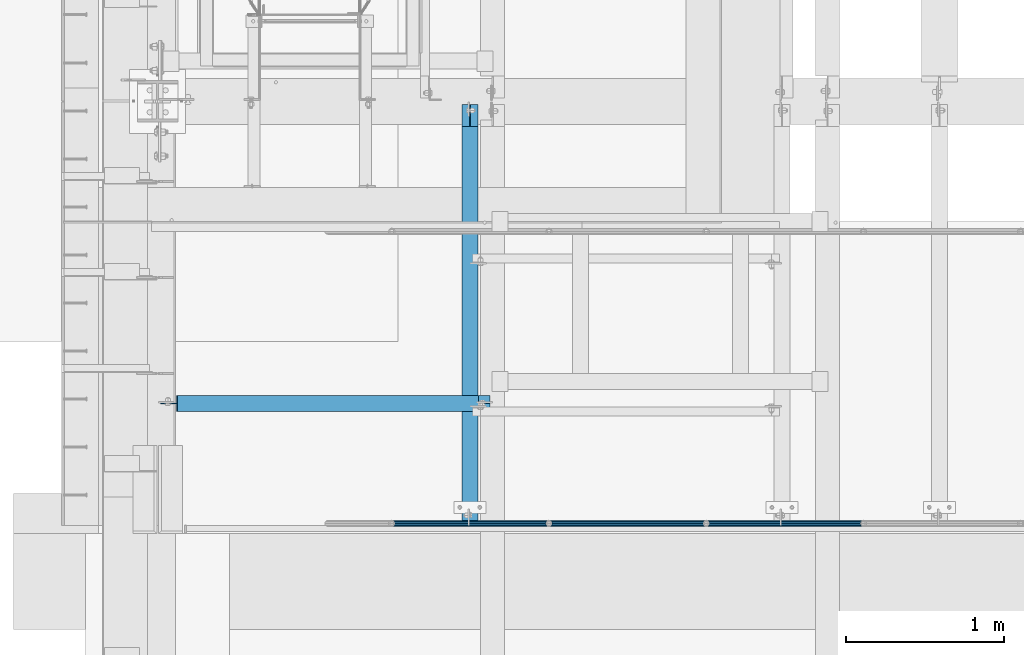
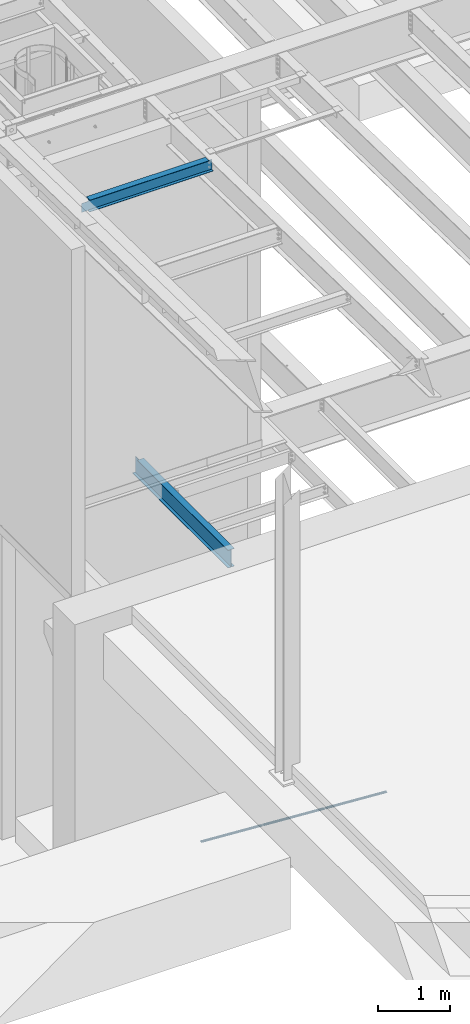
# One storey, part 1073 of 1763: 5 beams, 3 elements without a shape of their own.
"""IFC2X3 building model written with IfcOpenShell, lengths in millimetres."""

from ifc_helpers import new_model, si_unit, frame, origin_with_axes, place, context, subcontext, project, spatial, faceted_brep, material, type_object, element, aggregate, save


model = new_model("IFC2X3")

# Units and contexts
model_context = context("Model", 3, precision=1e-05, world=origin_with_axes())
body_context = subcontext(model_context, "Body", "Model", "MODEL_VIEW")
ifc_project = project(units=[si_unit("LENGTHUNIT", "METRE", prefix="MILLI"), si_unit("AREAUNIT", "SQUARE_METRE"), si_unit("VOLUMEUNIT", "CUBIC_METRE"), si_unit("MASSUNIT", "GRAM", prefix="KILO"), si_unit("TIMEUNIT", "SECOND"), si_unit("PLANEANGLEUNIT", "RADIAN"), si_unit("SOLIDANGLEUNIT", "STERADIAN"), si_unit("THERMODYNAMICTEMPERATUREUNIT", "DEGREE_CELSIUS"), si_unit("LUMINOUSINTENSITYUNIT", "LUMEN")], contexts=[model_context])

# Site, building, storey
site_placement = place(None, origin_with_axes())
site = spatial("IfcSite", under=ifc_project, at=site_placement, CompositionType="ELEMENT")
building_placement = place(site_placement, origin_with_axes())
building = spatial("IfcBuilding", under=site, at=building_placement, Name="Undefined", CompositionType="ELEMENT")
storey_placement = place(building_placement, origin_with_axes())
storey = spatial("IfcBuildingStorey", under=building, at=storey_placement, Name="Undefined", CompositionType="ELEMENT", Elevation=0.0)

# Assembly, beams
assembly_1_placement = place(storey_placement, origin_with_axes())
assembly_1 = element("IfcElementAssembly", 1, at=assembly_1_placement, inside=storey, Name="GUARDRAIL", AssemblyPlace="NOTDEFINED", PredefinedType="RIGID_FRAME")
ifc_material_1 = material()
beam_type_1 = type_object("IfcBeamType", PredefinedType="NOTDEFINED")
beam_1_placement = place(assembly_1_placement, frame((-84891.4958692838, 27343.0999999971, 342.725435582879), z_axis=(0.0, -1.0, 0.0), x_axis=(-0.997891522550524, 0.0, 0.0649038459707657)))
beam_1 = element("IfcBeam", 2, at=beam_1_placement, type_object=beam_type_1, material=ifc_material_1, Name="GUARDRAIL", context=body_context, shape_type="Brep", body=[
    faceted_brep([(1.45519152283669e-11, 1.81898940354586e-12, 19.0499999999993), (8.92561031517107, 9.52499999999873, 16.4977839420935), (10.1646410493704, -9.524999999996, 16.4977839420935), (10.1646410493704, -9.52499999999509, -16.4977839420935), (8.92561031517107, 9.52499999999873, -16.4977839420935), (1.45519152283669e-11, 1.81898940354586e-12, -19.0499999999993), (17.6056747381954, -16.4977839420881, -9.52500000000146), (17.2784488961188, -11.4667123799518, -9.52500000000146), (13.2411789904436, -7.68349999999555, -13.3082123799541), (10.6782988949999, 1.81898940354586e-12, -15.3669999999984), (12.2416941982665, 7.68350000000009, -13.3082123799541), (15.7868363965099, 11.4667123799545, -9.52500000000146), (15.4596105544624, 16.4977839420917, -9.52500000000146), (18.0907665723062, 15.3669999999984, 0.0), (17.8512206303712, 19.0499999999975, 0.0), (16.1615344449092, 13.3082123799541, -7.68349999999919), (16.1615344449092, 13.3082123799541, 7.68349999999919), (15.7868363965099, 11.4667123799545, 9.52500000000146), (15.4596105544624, 16.4977839420917, 9.52500000000146), (12.2416941982665, 7.68350000000009, 13.3082123799541), (10.6782988949999, 1.81898940354586e-12, 15.3669999999984), (13.2411789904436, -7.68349999999646, 13.3082123799541), (17.2784488961188, -11.4667123799518, 9.52500000000146), (17.6056747381954, -16.4977839420881, 9.52500000000146), (17.8926928863511, -13.3082123799504, 7.68349999999919), (20.0897361567768, -15.3669999999947, 0.0), (20.3292820987263, -19.0499999999938, 0.0), (17.8926928863511, -13.3082123799504, -7.68349999999919), (1000.15019855546, 2.72848410531878e-11, 19.0499999999993), (989.985557506108, 9.5250000000251, 16.4977839420935), (982.544523817283, 16.4977839421163, 9.52500000000146), (1000.15019855548, 2.81943357549608e-11, -19.0499999999993), (989.985557506108, 9.5250000000251, -16.4977839420935), (991.224588240293, -9.52499999997053, -16.4977839420935), (984.690588001031, -16.4977839420635, -9.52500000000146), (982.544523817283, 16.4977839421163, -9.52500000000146), (979.820916456767, 19.050000000022, 0.0), (982.257505670044, 13.3082123799786, 7.68349999999919), (980.060462398702, 15.3670000000229, 0.0), (982.87174965936, 11.46671237998, 9.52500000000146), (982.87174965936, 11.46671237998, -9.52500000000146), (982.257505670044, 13.3082123799786, -7.68349999999919), (986.909019565966, 7.68350000002556, -13.3082123799541), (989.47189966141, 2.81943357549608e-11, -15.3669999999984), (987.908504358144, -7.68349999997099, -13.3082123799541), (984.363362158969, -11.4667123799254, -9.52500000000146), (983.988664111486, -13.3082123799259, -7.68349999999919), (982.059431983173, -15.3669999999702, 0.0), (982.298977925122, -19.0499999999693, 0.0), (984.690588001031, -16.4977839420635, 9.52500000000146), (991.224588240293, -9.52499999997053, 16.4977839420935), (984.363362158969, -11.4667123799254, 9.52500000000146), (987.908504358144, -7.68349999997099, 13.3082123799541), (989.47189966141, 2.72848410531878e-11, 15.3669999999984), (986.909019565966, 7.68350000002465, 13.3082123799541), (983.988664111486, -13.3082123799259, 7.68349999999919)], [[[0, 1, 2]], [[3, 4, 5]], [[6, 7, 8, 9, 10, 11, 12, 4, 3]], [[13, 14, 12, 11, 15]], [[16, 17, 18, 14, 13]], [[2, 1, 18, 17, 19, 20, 21, 22, 23]], [[23, 22, 24, 25, 26]], [[26, 25, 27, 7, 6]], [[28, 29, 1, 0]], [[29, 30, 18, 1]], [[31, 32, 33]], [[33, 34, 6, 3]], [[31, 33, 3, 5]], [[32, 31, 5, 4]], [[35, 32, 4, 12]], [[36, 35, 12, 14]], [[30, 36, 14, 18]], [[37, 38, 36, 30, 39]], [[40, 35, 36, 38, 41]], [[33, 32, 35, 40, 42, 43, 44, 45, 34]], [[34, 45, 46, 47, 48]], [[34, 48, 26, 6]], [[49, 50, 2, 23]], [[48, 49, 23, 26]], [[50, 28, 0, 2]], [[28, 50, 29]], [[49, 51, 52, 53, 54, 39, 30, 29, 50]], [[48, 47, 55, 51, 49]], [[55, 47, 25, 24]], [[21, 52, 51, 55, 24, 22]], [[53, 52, 21, 20]], [[54, 53, 20, 19]], [[37, 39, 54, 19, 17, 16]], [[38, 37, 16, 13]], [[41, 38, 13, 15]], [[10, 42, 40, 41, 15, 11]], [[43, 42, 10, 9]], [[44, 43, 9, 8]], [[46, 45, 44, 8, 7, 27]], [[47, 46, 27, 25]]]),
])
beam_2_placement = place(assembly_1_placement, frame((-83893.4544648736, 27343.0999999971, 277.811841144733), z_axis=(0.0, -1.0, 0.0), x_axis=(-0.997891522550524, 0.0, 0.0649038459707657)))
beam_2 = element("IfcBeam", 3, at=beam_2_placement, type_object=beam_type_1, material=ifc_material_1, Name="GUARDRAIL", context=body_context, shape_type="Brep", body=[
    faceted_brep([(1000.15019855548, 2.81943357549608e-11, -19.0499999999993), (989.985557506108, 9.5250000000251, -16.4977839420935), (991.224588240293, -9.52499999997053, -16.4977839420935), (982.257505670044, 13.3082123799786, 7.68349999999919), (980.060462398702, 15.3670000000229, 0.0), (979.820916456767, 19.050000000022, 0.0), (982.544523817283, 16.4977839421163, 9.52500000000146), (982.87174965936, 11.46671237998, 9.52500000000146), (982.87174965936, 11.46671237998, -9.52500000000146), (982.544523817283, 16.4977839421163, -9.52500000000146), (982.257505670044, 13.3082123799786, -7.68349999999919), (986.909019565966, 7.68350000002556, -13.3082123799541), (989.47189966141, 2.81943357549608e-11, -15.3669999999984), (987.908504358144, -7.68349999997099, -13.3082123799541), (984.363362158969, -11.4667123799254, -9.52500000000146), (984.690588001031, -16.4977839420635, -9.52500000000146), (983.988664111486, -13.3082123799259, -7.68349999999919), (982.059431983173, -15.3669999999702, 0.0), (982.298977925122, -19.0499999999693, 0.0), (983.988664111486, -13.3082123799259, 7.68349999999919), (984.363362158969, -11.4667123799254, 9.52500000000146), (984.690588001031, -16.4977839420635, 9.52500000000146), (1000.15019855546, 2.72848410531878e-11, 19.0499999999993), (991.224588240293, -9.52499999997053, 16.4977839420935), (989.985557506108, 9.5250000000251, 16.4977839420935), (987.908504358144, -7.68349999997099, 13.3082123799541), (989.47189966141, 2.72848410531878e-11, 15.3669999999984), (986.909019565966, 7.68350000002465, 13.3082123799541), (8.92561031517107, 9.52499999999873, -16.4977839420935), (15.4596105544624, 16.4977839420917, -9.52500000000146), (17.8512206303712, 19.0499999999975, 0.0), (18.0907665723062, 15.3669999999984, 0.0), (15.7868363965099, 11.4667123799545, -9.52500000000146), (16.1615344449092, 13.3082123799541, -7.68349999999919), (16.1615344449092, 13.3082123799541, 7.68349999999919), (15.7868363965099, 11.4667123799545, 9.52500000000146), (15.4596105544624, 16.4977839420917, 9.52500000000146), (8.92561031517107, 9.52499999999873, 16.4977839420935), (1.45519152283669e-11, 1.81898940354586e-12, 19.0499999999993), (10.1646410493704, -9.524999999996, 16.4977839420935), (10.1646410493704, -9.52499999999509, -16.4977839420935), (1.45519152283669e-11, 1.81898940354586e-12, -19.0499999999993), (17.6056747381954, -16.4977839420881, -9.52500000000146), (20.3292820987263, -19.0499999999938, 0.0), (17.6056747381954, -16.4977839420881, 9.52500000000146), (17.2784488961188, -11.4667123799518, -9.52500000000146), (13.2411789904436, -7.68349999999555, -13.3082123799541), (10.6782988949999, 1.81898940354586e-12, -15.3669999999984), (12.2416941982665, 7.68350000000009, -13.3082123799541), (20.0897361567768, -15.3669999999947, 0.0), (17.8926928863511, -13.3082123799504, -7.68349999999919), (17.2784488961188, -11.4667123799518, 9.52500000000146), (17.8926928863511, -13.3082123799504, 7.68349999999919), (12.2416941982665, 7.68350000000009, 13.3082123799541), (10.6782988949999, 1.81898940354586e-12, 15.3669999999984), (13.2411789904436, -7.68349999999646, 13.3082123799541)], [[[0, 1, 2]], [[3, 4, 5, 6, 7]], [[8, 9, 5, 4, 10]], [[2, 1, 9, 8, 11, 12, 13, 14, 15]], [[15, 14, 16, 17, 18]], [[18, 17, 19, 20, 21]], [[22, 23, 24]], [[21, 20, 25, 26, 27, 7, 6, 24, 23]], [[9, 1, 28, 29]], [[5, 9, 29, 30]], [[31, 30, 29, 32, 33]], [[34, 35, 36, 30, 31]], [[6, 5, 30, 36]], [[24, 6, 36, 37]], [[22, 24, 37, 38]], [[38, 37, 39]], [[0, 2, 40, 41]], [[2, 15, 42, 40]], [[15, 18, 43, 42]], [[18, 21, 44, 43]], [[21, 23, 39, 44]], [[23, 22, 38, 39]], [[1, 0, 41, 28]], [[40, 28, 41]], [[42, 45, 46, 47, 48, 32, 29, 28, 40]], [[43, 49, 50, 45, 42]], [[44, 51, 52, 49, 43]], [[39, 37, 36, 35, 53, 54, 55, 51, 44]], [[26, 25, 55, 54]], [[55, 25, 20, 19, 52, 51]], [[19, 17, 49, 52]], [[17, 16, 50, 49]], [[16, 14, 13, 46, 45, 50]], [[13, 12, 47, 46]], [[12, 11, 48, 47]], [[48, 11, 8, 10, 33, 32]], [[10, 4, 31, 33]], [[4, 3, 34, 31]], [[3, 7, 27, 53, 35, 34]], [[27, 26, 54, 53]]]),
])
beam_3_placement = place(assembly_1_placement, frame((-82895.4130604548, 27343.0999999971, 212.898246706025), z_axis=(0.0, -1.0, 0.0), x_axis=(-0.997891522550524, 0.0, 0.0649038459707657)))
beam_3 = element("IfcBeam", 4, at=beam_3_placement, type_object=beam_type_1, material=ifc_material_1, Name="GUARDRAIL", context=body_context, shape_type="Brep", body=[
    faceted_brep([(1000.15019855548, 2.81943357549608e-11, -19.0499999999993), (989.985557506108, 9.5250000000251, -16.4977839420935), (991.224588240293, -9.52499999997053, -16.4977839420935), (982.257505670044, 13.3082123799786, 7.68349999999919), (980.060462398702, 15.3670000000229, 0.0), (979.820916456767, 19.050000000022, 0.0), (982.544523817283, 16.4977839421163, 9.52500000000146), (982.87174965936, 11.46671237998, 9.52500000000146), (982.87174965936, 11.46671237998, -9.52500000000146), (982.544523817283, 16.4977839421163, -9.52500000000146), (982.257505670044, 13.3082123799786, -7.68349999999919), (986.909019565966, 7.68350000002556, -13.3082123799541), (989.47189966141, 2.81943357549608e-11, -15.3669999999984), (987.908504358144, -7.68349999997099, -13.3082123799541), (984.363362158969, -11.4667123799254, -9.52500000000146), (984.690588001031, -16.4977839420635, -9.52500000000146), (983.988664111486, -13.3082123799259, -7.68349999999919), (982.059431983173, -15.3669999999702, 0.0), (982.298977925122, -19.0499999999693, 0.0), (983.988664111486, -13.3082123799259, 7.68349999999919), (984.363362158969, -11.4667123799254, 9.52500000000146), (984.690588001031, -16.4977839420635, 9.52500000000146), (1000.15019855546, 2.72848410531878e-11, 19.0499999999993), (991.224588240293, -9.52499999997053, 16.4977839420935), (989.985557506108, 9.5250000000251, 16.4977839420935), (987.908504358144, -7.68349999997099, 13.3082123799541), (989.47189966141, 2.72848410531878e-11, 15.3669999999984), (986.909019565966, 7.68350000002465, 13.3082123799541), (8.92561031517107, 9.52499999999873, -16.4977839420935), (15.4596105544624, 16.4977839420917, -9.52500000000146), (17.8512206303712, 19.0499999999975, 0.0), (18.0907665723062, 15.3669999999984, 0.0), (15.7868363965099, 11.4667123799545, -9.52500000000146), (16.1615344449092, 13.3082123799541, -7.68349999999919), (16.1615344449092, 13.3082123799541, 7.68349999999919), (15.7868363965099, 11.4667123799545, 9.52500000000146), (15.4596105544624, 16.4977839420917, 9.52500000000146), (8.92561031517107, 9.52499999999873, 16.4977839420935), (1.45519152283669e-11, 1.81898940354586e-12, 19.0499999999993), (10.1646410493704, -9.524999999996, 16.4977839420935), (10.1646410493704, -9.52499999999509, -16.4977839420935), (1.45519152283669e-11, 1.81898940354586e-12, -19.0499999999993), (17.6056747381954, -16.4977839420881, -9.52500000000146), (20.3292820987263, -19.0499999999938, 0.0), (17.6056747381954, -16.4977839420881, 9.52500000000146), (17.2784488961188, -11.4667123799518, -9.52500000000146), (13.2411789904436, -7.68349999999555, -13.3082123799541), (10.6782988949999, 1.81898940354586e-12, -15.3669999999984), (12.2416941982665, 7.68350000000009, -13.3082123799541), (20.0897361567768, -15.3669999999947, 0.0), (17.8926928863511, -13.3082123799504, -7.68349999999919), (17.2784488961188, -11.4667123799518, 9.52500000000146), (17.8926928863511, -13.3082123799504, 7.68349999999919), (12.2416941982665, 7.68350000000009, 13.3082123799541), (10.6782988949999, 1.81898940354586e-12, 15.3669999999984), (13.2411789904436, -7.68349999999646, 13.3082123799541)], [[[0, 1, 2]], [[3, 4, 5, 6, 7]], [[8, 9, 5, 4, 10]], [[2, 1, 9, 8, 11, 12, 13, 14, 15]], [[15, 14, 16, 17, 18]], [[18, 17, 19, 20, 21]], [[22, 23, 24]], [[21, 20, 25, 26, 27, 7, 6, 24, 23]], [[9, 1, 28, 29]], [[5, 9, 29, 30]], [[31, 30, 29, 32, 33]], [[34, 35, 36, 30, 31]], [[6, 5, 30, 36]], [[24, 6, 36, 37]], [[22, 24, 37, 38]], [[38, 37, 39]], [[0, 2, 40, 41]], [[2, 15, 42, 40]], [[15, 18, 43, 42]], [[18, 21, 44, 43]], [[21, 23, 39, 44]], [[23, 22, 38, 39]], [[1, 0, 41, 28]], [[40, 28, 41]], [[42, 45, 46, 47, 48, 32, 29, 28, 40]], [[43, 49, 50, 45, 42]], [[44, 51, 52, 49, 43]], [[39, 37, 36, 35, 53, 54, 55, 51, 44]], [[26, 25, 55, 54]], [[55, 25, 20, 19, 52, 51]], [[19, 17, 49, 52]], [[17, 16, 50, 49]], [[16, 14, 13, 46, 45, 50]], [[13, 12, 47, 46]], [[12, 11, 48, 47]], [[48, 11, 8, 10, 33, 32]], [[10, 4, 31, 33]], [[4, 3, 34, 31]], [[3, 7, 27, 53, 35, 34]], [[27, 26, 54, 53]]]),
])
aggregate(assembly_1, [beam_1, beam_2, beam_3])

# Assembly, beam
assembly_2_placement = place(storey_placement, origin_with_axes())
assembly_2 = element("IfcElementAssembly", 5, at=assembly_2_placement, inside=storey, Name="BEAM", AssemblyPlace="NOTDEFINED", PredefinedType="RIGID_FRAME")
ifc_material_2 = material(Name="STEEL/A992")
beam_type_2 = type_object("IfcBeamType", Name="W8X10", PredefinedType="NOTDEFINED")
beam_4_placement = place(assembly_2_placement, frame((-87375.4372736983, 28105.1, 11230.3787873104), z_axis=(0.0, 0.0, 1.0), x_axis=(1.0, 0.0, 0.0)))
beam_4 = element("IfcBeam", 6, at=beam_4_placement, type_object=beam_type_2, material=ifc_material_2, Name="BEAM", ObjectType="W8X10", context=body_context, shape_type="Brep", body=[
    faceted_brep([(2036.64910714288, -50.7999999999993, 100.012500000001), (2036.64910714288, -50.7999999999993, 95.25), (2036.64910714288, -2.38124999999854, 95.25), (2036.64910714288, -2.38124999999854, 82.2900014933966), (2036.64910714288, 2.38124999999854, 82.2900014933966), (2036.64910714288, 2.38124999999854, 95.25), (2036.64910714288, 50.7999999999993, 95.25), (2036.64910714288, 50.7999999999993, 100.012500000001), (2037.61583706546, -2.38124999999854, 77.4299219753502), (2037.61583706546, 2.38124999999854, 77.4299219753502), (2040.36885096594, -2.38124999999854, 73.3097455071966), (2040.36885096594, 2.38124999999854, 73.3097455071966), (2044.4890274341, -2.38124999999854, 70.556731606719), (2044.4890274341, 2.38124999999854, 70.556731606719), (2049.34910695214, -2.38124999999854, 69.5900016841315), (2049.34910695214, 2.38124999999854, 69.5900016841315), (2109.67410714287, -2.38124999999854, 69.5900016942032), (2109.67410714287, 2.38124999999854, 69.5900016942032), (126.206249999988, -50.7999999999993, 100.012500000001), (126.206249999988, 50.7999999999993, 100.012500000001), (126.206249999988, 50.7999999999993, 95.25), (126.206249999988, 2.38124999999854, 95.25), (126.206249999988, 2.38124999999854, 63.2400015018902), (126.206249999988, -2.38124999999854, 63.2400015018902), (126.206249999988, -2.38124999999854, 95.25), (126.206249999988, -50.7999999999993, 95.25), (125.239520077404, 2.38124999999854, 58.3799219838438), (125.239520077404, -2.38124999999854, 58.3799219838438), (122.486506176923, 2.38124999999854, 54.2597455156902), (122.486506176923, -2.38124999999854, 54.2597455156902), (118.366329708762, 2.38124999999854, 51.5067316152126), (118.366329708762, -2.38124999999854, 51.5067316152126), (113.506250190723, 2.38124999999854, 50.5400016926251), (113.506250190723, -2.38124999999854, 50.5400016926251), (18.2562499999913, 2.38124999999854, 50.5400016926251), (18.2562499999913, -2.38124999999854, 50.5400016926251), (18.2562499999913, 2.38124999999854, -95.25), (2109.67410714287, 2.38124999999854, -95.25), (2109.67410714287, 50.7999999999993, -95.25), (119.856253956619, 50.7999999999993, -95.25), (119.856292066746, 2.68114264835822, -95.25), (18.2562499999913, 2.6810621808836, -95.25), (18.2562499999913, -2.68143481797597, -95.25), (18.2562499999913, -2.68122318676615, -100.012500000001), (119.856294836529, -2.68114271968443, -100.012500000001), (119.856294836674, -2.68135435090517, -95.25), (18.2562499999913, -2.38124999999854, -95.25), (18.2562499999913, 2.68127381209342, -100.012500000001), (119.856292066615, 2.68135427957895, -100.012500000001), (119.856253956619, 50.7999999999993, -100.012500000001), (2109.67410714287, 50.7999999999993, -100.012500000001), (2109.67410714287, -50.7999999999993, -100.012500000001), (2109.67410714287, -50.7999999999993, -95.25), (119.856332946641, -50.7999999999993, -95.25), (119.856332946641, -50.7999999999993, -100.012500000001), (2109.67410714287, -2.38124999999854, -95.25)], [[[0, 1, 2, 3, 4, 5, 6, 7]], [[8, 9, 4, 3]], [[10, 11, 9, 8]], [[12, 13, 11, 10]], [[14, 15, 13, 12]], [[16, 17, 15, 14]], [[18, 19, 20, 21, 22, 23, 24, 25]], [[23, 22, 26, 27]], [[27, 26, 28, 29]], [[29, 28, 30, 31]], [[31, 30, 32, 33]], [[33, 32, 34, 35]], [[36, 37, 38, 39, 40, 41]], [[42, 43, 44, 45]], [[46, 35, 34, 36, 41, 47, 43, 42]], [[40, 48, 47, 41]], [[39, 49, 48, 40]], [[38, 50, 49, 39]], [[51, 52, 53, 54]], [[43, 47, 48, 49, 50, 51, 54, 44]], [[53, 45, 44, 54]], [[52, 55, 46, 42, 45, 53]], [[12, 10, 8, 3, 2, 24, 23, 27, 29, 31, 33, 35, 46, 55, 16, 14]], [[25, 24, 2, 1]], [[18, 25, 1, 0]], [[19, 18, 0, 7]], [[20, 19, 7, 6]], [[21, 20, 6, 5]], [[37, 36, 34, 32, 30, 28, 26, 22, 21, 5, 4, 9, 11, 13, 15, 17]], [[55, 52, 51, 50, 38, 37, 17, 16]]]),
])
aggregate(assembly_2, [beam_4])

assembly_3_placement = place(storey_placement, origin_with_axes())
assembly_3 = element("IfcElementAssembly", 7, at=assembly_3_placement, inside=storey, Name="BEAM", AssemblyPlace="NOTDEFINED", PredefinedType="RIGID_FRAME")
beam_type_3 = type_object("IfcBeamType", Name="W12X16", PredefinedType="NOTDEFINED")
beam_5_placement = place(assembly_3_placement, frame((-85394.1576116291, 27279.6, 5041.9), z_axis=(0.0, 0.0, 1.0), x_axis=(0.0, 1.0, 0.0)))
beam_5 = element("IfcBeam", 8, at=beam_5_placement, type_object=beam_type_3, material=ifc_material_2, Name="BEAM", ObjectType="W12X16", context=body_context, shape_type="Brep", body=[
    faceted_brep([(63.5000000000036, -3.17499999999927, -146.05), (63.5000000000036, -50.7999999999993, -146.05), (2723.35625, -50.8000000000029, -146.05), (2723.35625, -3.17500000000291, -146.05), (63.5000000000036, -50.7999999999993, -152.4), (2723.35625, -50.8000000000029, -152.4), (63.5000000000036, 50.7999999999993, -152.4), (2723.35625, 50.8000000000029, -152.4), (63.5000000000036, 50.7999999999993, -146.05), (63.5000000000036, 3.17499999999927, -146.05), (2723.35625, 3.17500000000291, -146.05), (2723.35625, 50.8000000000029, -146.05), (2723.35625, 3.17500000000291, 120.390001678466), (2723.35625, -3.17500000000291, 120.390001678466), (63.5000000000036, -3.17499999999927, 146.05), (63.5000000000036, -50.7999999999993, 146.05), (63.5000000000036, -50.7999999999993, 152.4), (63.5000000000036, 50.7999999999993, 152.4), (63.5000000000036, 50.7999999999993, 146.05), (63.5000000000036, 3.17499999999927, 146.05), (2583.65625, 50.8000000000029, 146.05), (2583.65625, 3.17500000000291, 146.05), (2583.65625, 3.17500000000291, 133.090001487732), (2584.62297992259, 3.17500000000291, 128.229921969686), (2587.37599382307, 3.17500000000291, 124.109745501532), (2591.49617029122, 3.17500000000291, 121.356731601054), (2596.35624980927, 3.17500000000291, 120.390001678466), (2584.62297992259, -3.17500000000291, 128.229921969686), (2583.65625, -3.17500000000291, 133.090001487732), (2587.37599382307, -3.17500000000291, 124.109745501532), (2591.49617029122, -3.17500000000291, 121.356731601054), (2596.35624980927, -3.17500000000291, 120.390001678466), (2583.65625, -3.17500000000291, 146.05), (2583.65625, -50.8000000000029, 146.05), (2583.65625, -50.8000000000029, 152.4), (2583.65625, 50.8000000000029, 152.4)], [[[0, 1, 2, 3]], [[1, 4, 5, 2]], [[4, 6, 7, 5]], [[8, 9, 10, 11]], [[3, 2, 5, 7, 11, 10, 12, 13]], [[6, 8, 11, 7]], [[4, 1, 0, 14, 15, 16, 17, 18, 19, 9, 8, 6]], [[19, 18, 20, 21]], [[10, 9, 19, 21, 22, 23, 24, 25, 26, 12]], [[27, 23, 22, 28]], [[29, 24, 23, 27]], [[30, 25, 24, 29]], [[31, 26, 25, 30]], [[13, 12, 26, 31]], [[30, 29, 27, 28, 32, 14, 0, 3, 13, 31]], [[15, 14, 32, 33]], [[16, 15, 33, 34]], [[17, 16, 34, 35]], [[18, 17, 35, 20]], [[34, 33, 32, 28, 22, 21, 20, 35]]]),
])
aggregate(assembly_3, [beam_5])

save(model, "model.ifc")
